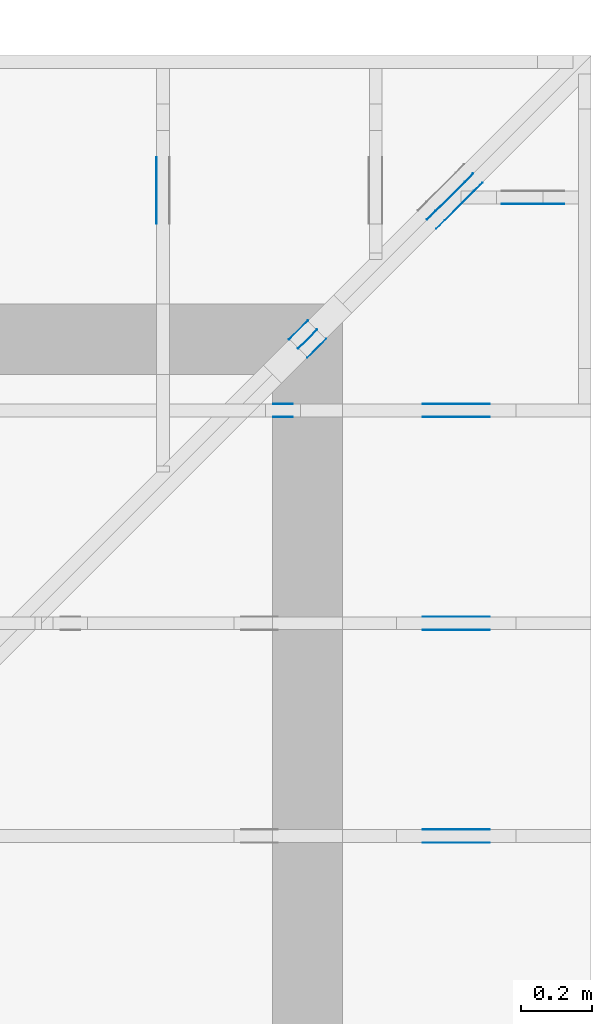
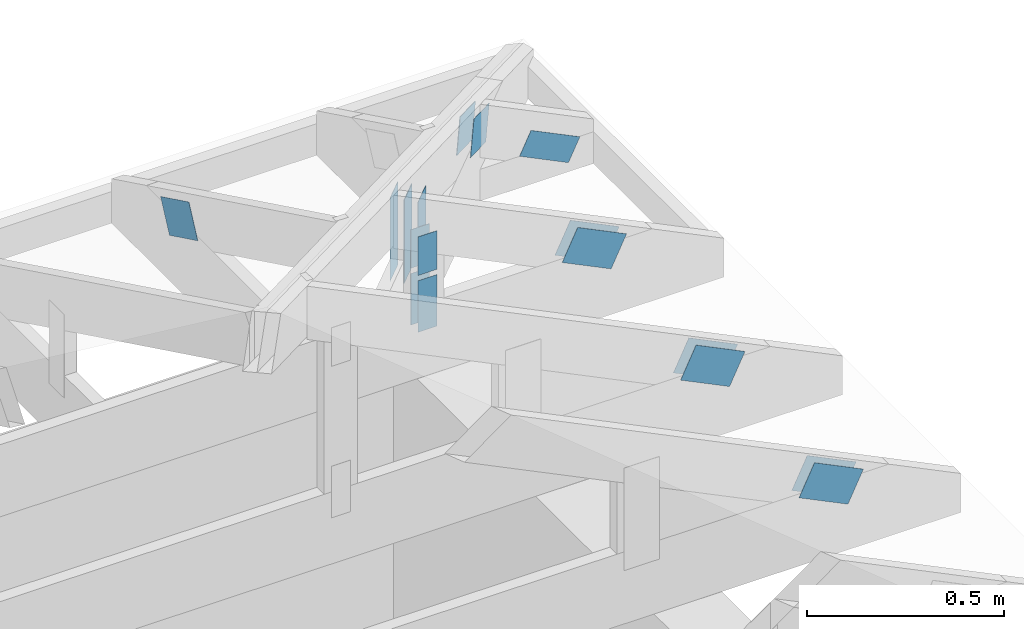
# One storey, part 135 of 159: 19 plates, 6 elements without a shape of their own.
"""IFC2X3 building model written with IfcOpenShell, lengths in millimetres."""

import ifcopenshell
import ifcopenshell.guid

model = None  # the IFC model being written
_history = None  # IfcOwnerHistory: only IFC2X3 demands one
_inside = {}  # id of a spatial element -> (the spatial element, [elements in it])
_under = {}  # id of a project, library or spatial element -> (it, [spatial elements below it])
_declared = {}  # id of a project -> (the project, [libraries it declares])
_typed = {}  # id of a type object -> (the type object, [elements of that type])
_made_of = {}  # id of a material, layer set ... -> (it, [elements and type objects made of it])


def new_model(schema):
    """Start an empty IFC model of exactly this schema.

    Asked for "IFC4X3", IfcOpenShell would pick the latest addendum, in which some entities
    have other attributes; the version numbers below select the first issue.
    IFC2X3 requires an IfcOwnerHistory on every rooted entity: one is made here for all.
    """
    global model, _history
    if schema == "IFC4X3":
        model = ifcopenshell.file(schema_version=(4, 3, 0, 0))
    else:
        model = ifcopenshell.file(schema=schema)
    _inside.clear()
    _under.clear()
    _declared.clear()
    _typed.clear()
    _made_of.clear()
    _history = None
    if model.schema == "IFC2X3":
        org = make("IfcOrganization", Name="unknown")
        user = make(
            "IfcPersonAndOrganization",
            ThePerson=make("IfcPerson", FamilyName="unknown"),
            TheOrganization=org,
        )
        app = make(
            "IfcApplication",
            ApplicationDeveloper=org,
            Version="unknown",
            ApplicationFullName="unknown",
            ApplicationIdentifier="unknown",
        )
        _history = make(
            "IfcOwnerHistory",
            OwningUser=user,
            OwningApplication=app,
            ChangeAction="ADDED",
            CreationDate=0,
        )
    return model


def make(cls, **values):
    """One entity of the class cls with the attributes given. An attribute that is None is left unset."""
    return model.create_entity(
        cls, **{name: value for name, value in values.items() if value is not None}
    )


def rooted(cls, **values):
    """An entity with a GlobalId (a new one), such as an element, a storey or a relation."""
    return make(cls, GlobalId=ifcopenshell.guid.new(), OwnerHistory=_history, **values)


def si_unit(unit_type, name, prefix=None):
    """IfcSIUnit, for example si_unit("LENGTHUNIT", "METRE", prefix="MILLI")."""
    return make("IfcSIUnit", UnitType=unit_type, Prefix=prefix, Name=name)


def assignment(units):
    """IfcUnitAssignment: the units of a project."""
    return None if units is None else make("IfcUnitAssignment", Units=units)


def point(xyz):
    """IfcCartesianPoint."""
    return None if xyz is None else make("IfcCartesianPoint", Coordinates=xyz)


def direction(xyz):
    """IfcDirection."""
    return None if xyz is None else make("IfcDirection", DirectionRatios=xyz)


def frame(location, z_axis=None, x_axis=None):
    """IfcAxis2Placement3D, a coordinate frame: its origin and axes. An axis left out is left unset."""
    return make(
        "IfcAxis2Placement3D",
        Location=point(location),
        Axis=direction(z_axis),
        RefDirection=direction(x_axis),
    )


def frame_2d(location, x_axis=None):
    """IfcAxis2Placement2D, a coordinate frame in the plane: its origin and x axis."""
    return make(
        "IfcAxis2Placement2D", Location=point(location), RefDirection=direction(x_axis)
    )


def origin():
    """The frame at (0, 0, 0) with its axes left unset."""
    return frame((0.0, 0.0, 0.0))


def origin_with_axes():
    """The frame at (0, 0, 0) with the z axis (0, 0, 1) and the x axis (1, 0, 0) written out."""
    return frame((0.0, 0.0, 0.0), z_axis=(0.0, 0.0, 1.0), x_axis=(1.0, 0.0, 0.0))


def origin_2d():
    """The frame at (0, 0) in the plane with its x axis left unset."""
    return frame_2d((0.0, 0.0))


def place(relative_to, where):
    """IfcLocalPlacement: puts the frame where relative to a parent placement (None: the world)."""
    return make(
        "IfcLocalPlacement", PlacementRelTo=relative_to, RelativePlacement=where
    )


def context(
    kind, dimensions, precision=None, world=None, true_north=None, identifier=None
):
    """IfcGeometricRepresentationContext, for example the 3D "Model" context."""
    return make(
        "IfcGeometricRepresentationContext",
        ContextIdentifier=identifier,
        ContextType=kind,
        CoordinateSpaceDimension=dimensions,
        Precision=precision,
        WorldCoordinateSystem=world,
        TrueNorth=true_north,
    )


def project(units=None, contexts=None):
    """IfcProject with its units and contexts."""
    return rooted(
        "IfcProject",
        Name="project",
        RepresentationContexts=contexts,
        UnitsInContext=assignment(units),
    )


def spatial(cls, under=None, at=None, **own):
    """A site, building, storey or space (cls), placed at a placement, below another one or the project."""
    s = rooted(cls, ObjectPlacement=at, **own)
    if under is not None:
        _under.setdefault(under.id(), (under, []))[1].append(s)
    return s


def faces_of(points, faces, orient=None, outer=None):
    """IfcFace entities. A face is a list of loops; a loop is a list of indices into points, from 0.

    orient and outer hold one flag for each loop. By default every Orientation is true, the
    first loop of a face is its IfcFaceOuterBound and the others are IfcFaceBound.
    """
    made = []
    for i, loops in enumerate(faces):
        bounds = []
        for j, loop in enumerate(loops):
            is_outer = j == 0 if outer is None else outer[i][j]
            bounds.append(
                make(
                    "IfcFaceOuterBound" if is_outer else "IfcFaceBound",
                    Bound=make("IfcPolyLoop", Polygon=[points[k] for k in loop]),
                    Orientation=True if orient is None else orient[i][j],
                )
            )
        made.append(make("IfcFace", Bounds=bounds))
    return made


def faceted_brep(points, faces, orient=None, outer=None, voids=None):
    """IfcFacetedBrep: a solid bounded by flat faces; with voids (closed shells), ...WithVoids."""
    shared = [point(p) for p in points]
    hull = make("IfcClosedShell", CfsFaces=faces_of(shared, faces, orient, outer))
    if voids is None:
        return make("IfcFacetedBrep", Outer=hull)
    return make(
        "IfcFacetedBrepWithVoids",
        Outer=hull,
        Voids=[
            make(cls, CfsFaces=faces_of(shared, fs, o, b)) for cls, fs, o, b in voids
        ],
    )


def shape(context_of_items, identifier, shape_type, items):
    """IfcShapeRepresentation: the items that make up one representation, for example the "Body"."""
    return make(
        "IfcShapeRepresentation",
        ContextOfItems=context_of_items,
        RepresentationIdentifier=identifier,
        RepresentationType=shape_type,
        Items=items,
    )


def made_of(thing, what):
    """Note that an element or type object is made of a material, layer set ...; save() writes the relation."""
    if what is not None:
        _made_of.setdefault(what.id(), (what, []))[1].append(thing)
    return thing


def element(
    cls,
    number,
    at=None,
    inside=None,
    cuts=None,
    type_object=None,
    material=None,
    context=None,
    identifier="Body",
    shape_type=None,
    held_by="IfcProductDefinitionShape",
    body=None,
    shapes=None,
    **own,
):
    """One element of the class cls, such as IfcWall. Its Tag is "e" and its number.

    at: its placement. inside: the storey or other place that contains it. cuts: it is an
    opening in that element (IfcRelVoidsElement). A single representation is given by context,
    identifier, shape_type and body (its items); several are given by shapes. held_by: the class
    of the entity that holds the representations. save() writes the other relations.
    """
    e = rooted(cls, Tag="e%d" % number, ObjectPlacement=at, **own)
    if body is not None:
        shapes = [shape(context, identifier, shape_type, body)]
    if shapes is not None:
        e.Representation = make(held_by, Representations=shapes)
    if inside is not None:
        _inside.setdefault(inside.id(), (inside, []))[1].append(e)
    if cuts is not None:
        rooted(
            "IfcRelVoidsElement", RelatingBuildingElement=cuts, RelatedOpeningElement=e
        )
    if type_object is not None:
        _typed.setdefault(type_object.id(), (type_object, []))[1].append(e)
    return made_of(e, material)


def aggregate(whole, parts):
    """IfcRelAggregates: a whole, such as a stair, and the parts it consists of."""
    return rooted("IfcRelAggregates", RelatingObject=whole, RelatedObjects=parts)


def save(model, path):
    """Write the relations noted so far, then the file.

    IfcRelAggregates (storeys below a building ...), IfcRelContainedInSpatialStructure (elements
    in a storey), IfcRelDefinesByType, IfcRelAssociatesMaterial and IfcRelDeclares: one each for
    every whole, place, type object, material and project.
    """
    for whole, parts in _under.values():
        aggregate(whole, parts)
    for where, things in _inside.values():
        rooted(
            "IfcRelContainedInSpatialStructure",
            RelatedElements=things,
            RelatingStructure=where,
        )
    for kind, things in _typed.values():
        rooted("IfcRelDefinesByType", RelatedObjects=things, RelatingType=kind)
    for what, things in _made_of.values():
        rooted("IfcRelAssociatesMaterial", RelatedObjects=things, RelatingMaterial=what)
    for by, libraries in _declared.values():
        rooted("IfcRelDeclares", RelatingContext=by, RelatedDefinitions=libraries)
    model.write(path)


model = new_model("IFC2X3")

# Units and contexts
model_context = context("Model", 3, precision=1e-05, world=origin())
plan_context = context("Plan", 2, precision=1e-05, world=origin_2d())
ifc_project = project(units=[si_unit("LENGTHUNIT", "METRE", prefix="MILLI"), si_unit("AREAUNIT", "SQUARE_METRE"), si_unit("VOLUMEUNIT", "CUBIC_METRE"), si_unit("SOLIDANGLEUNIT", "STERADIAN"), si_unit("PLANEANGLEUNIT", "RADIAN"), si_unit("MASSUNIT", "GRAM"), si_unit("TIMEUNIT", "SECOND"), si_unit("THERMODYNAMICTEMPERATUREUNIT", "DEGREE_CELSIUS"), si_unit("LUMINOUSINTENSITYUNIT", "LUMEN")], contexts=[model_context, plan_context])

# Site, building, storey
site_placement = place(None, origin_with_axes())
site = spatial("IfcSite", under=ifc_project, at=site_placement, CompositionType="ELEMENT")
building_placement = place(site_placement, origin_with_axes())
building = spatial("IfcBuilding", under=site, at=building_placement, Name="Plan 1", CompositionType="ELEMENT")
storey_placement = place(building_placement, origin_with_axes())
storey = spatial("IfcBuildingStorey", under=building, at=storey_placement, Name="Etasje 1", CompositionType="ELEMENT", Elevation=0.0)

# Assembly, plate
assembly_1_placement = place(storey_placement, frame((19875.02226140475, 9663.999999999993, 1.1021457184401395e-15), z_axis=(-1.0, 1.836909530733566e-16, 6.123031769111886e-17), x_axis=(-1.836909530733566e-16, -1.0, 0.0)))
assembly_1 = element("IfcElementAssembly", 1, at=assembly_1_placement, inside=storey, Name="S22 (57)", AssemblyPlace="FACTORY", PredefinedType="TRUSS")
plate_1_placement = place(assembly_1_placement, frame((295.1100155272948, 141.8615890385072, 0.0), z_axis=(0.0, 0.0, 1.0), x_axis=(0.898794046299167, 0.4383711467890774, 0.0)))
plate_1 = element("IfcPlate", 2, at=plate_1_placement, Name="GNT100S 103x159", context=model_context, shape_type="Brep", body=[
    faceted_brep([(158.9999923478332, 103.00001933830698, 1.0), (0.0, 103.00001933830698, 1.0), (6.332527107133501e-06, 1.220379553501516e-05, 1.0), (159.00001239486903, 1.220379553501516e-05, 1.0), (0.0, 103.00001933830698, 0.0), (158.9999923478332, 103.00001933830698, 1.947124008868659e-14), (159.00001239486903, 0.0, 1.9471242543659335e-14), (6.332527107133501e-06, 0.0, 7.754852931148123e-22), (159.0000031613913, 1.1149930599355426e-05, 4.8075179880833783e-32), (159.0000031613913, 1.1149930599416657e-05, 1.0), (3.1613913051842246e-06, 1.1149930628623518e-05, 1.0), (3.1613913051842246e-06, 1.1149930628562288e-05, 0.0), (159.0000031613913, 103.00001114993066, 0.0), (159.0000031613913, 103.00001114993066, 1.0), (159.0000031613913, 1.1149930600140578e-05, 1.0), (159.0000031613913, 1.1149930600140578e-05, 0.0), (3.1613913051842246e-06, 103.00001114993063, 0.0), (3.1613913051842246e-06, 103.00001114993063, 1.0), (159.0000031613913, 103.00001114993066, 1.0), (159.0000031613913, 103.00001114993066, 0.0), (3.161391305184226e-06, 1.1149930628562288e-05, -9.4039548065783e-38), (3.161391305245456e-06, 1.1149930628562288e-05, 1.0), (3.1613913178589017e-06, 103.00001114993063, 1.0), (3.1613913177976713e-06, 103.00001114993063, -7.723253437374298e-31)], [[[0, 1, 2, 3]], [[4, 5, 6, 7]], [[8, 9, 10, 11]], [[12, 13, 14, 15]], [[16, 17, 18, 19]], [[20, 21, 22, 23]]]),
])
aggregate(assembly_1, [plate_1])

# Assembly, plates
assembly_2_placement = place(storey_placement, frame((21100.012663101486, 8717.993668449257, 1.1021457184401395e-15), z_axis=(1.2246063538223773e-16, 1.0, 6.123031769111886e-17), x_axis=(-1.0, 1.2246063538223773e-16, 0.0)))
assembly_2 = element("IfcElementAssembly", 3, at=assembly_2_placement, inside=storey, Name="S20 (50)", AssemblyPlace="FACTORY", PredefinedType="TRUSS")
plate_2_placement = place(assembly_2_placement, frame((331.11001837099207, 141.86159042547106, 0.0), z_axis=(0.0, 0.0, 1.0), x_axis=(0.8987940462991673, 0.43837114678907685, 0.0)))
plate_2 = element("IfcPlate", 4, at=plate_2_placement, Name="GNT100S 103x159", context=model_context, shape_type="Brep", body=[
    faceted_brep([(158.99998918392998, 103.00001264929405, 1.0), (1.0550605622938747e-05, 103.00001264929405, 1.0), (3.168624004956655e-06, 1.2203795492382596e-05, 1.0), (159.00000923096593, 1.2203795492382596e-05, 1.0), (1.0550605622938747e-05, 103.00001264929405, 1.292033868252489e-21), (158.99998918392998, 103.00001264929405, 1.9471239701232992e-14), (159.00000923096593, 0.0, 1.947124215620575e-14), (3.168624004956655e-06, 0.0, 3.8803170893440275e-22), (159.0000000000001, 1.1148705922106925e-05, 2.6584805324637452e-30), (159.0000000000001, 1.1148705922168155e-05, 1.0), (5.684341886080802e-14, 1.1148705951375017e-05, 1.0), (5.684341886080802e-14, 1.1148705951313786e-05, 0.0), (159.0000000000001, 103.00001114870594, 0.0), (159.0000000000001, 103.00001114870594, 1.0), (159.0000000000001, 1.1148705965524641e-05, 1.0), (159.0000000000001, 1.1148705965524641e-05, 0.0), (-4.861730685829017e-63, 103.00001114870594, 0.0), (-3.7491518045553436e-33, 103.00001114870594, 1.0), (159.0000000000001, 103.00001114870592, 1.0), (159.0000000000001, 103.00001114870592, -7.888609052210118e-31), (5.684342142778951e-14, 1.1148705951313786e-05, -1.5717709276844939e-37), (5.690465174548063e-14, 1.1148705951313786e-05, 1.0), (2.377690857529467e-14, 103.00001114870594, 1.0), (2.3715678257603552e-14, 103.00001114870594, -1.4521185139734257e-30)], [[[0, 1, 2, 3]], [[4, 5, 6, 7]], [[8, 9, 10, 11]], [[12, 13, 14, 15]], [[16, 17, 18, 19]], [[20, 21, 22, 23]]]),
])
plate_3_placement = place(assembly_2_placement, frame((331.11001837099207, 141.86159042547106, -37.0), z_axis=(0.0, 0.0, 1.0), x_axis=(0.8987940462991673, 0.43837114678907685, 0.0)))
plate_3 = element("IfcPlate", 5, at=plate_3_placement, Name="GNT100S 103x159", context=model_context, shape_type="Brep", body=[
    faceted_brep([(158.99998918392998, 103.00001264929405, 1.0), (1.0550605622938747e-05, 103.00001264929405, 1.0), (3.168624004956655e-06, 1.2203795492382596e-05, 1.0), (159.00000923096593, 1.2203795492382596e-05, 1.0), (1.0550605622938747e-05, 103.00001264929405, 1.292033868252489e-21), (158.99998918392998, 103.00001264929405, 1.9471239701232992e-14), (159.00000923096593, 0.0, 1.947124215620575e-14), (3.168624004956655e-06, 0.0, 3.8803170893440275e-22), (159.0000000000001, 1.1148705922106925e-05, 2.6584805324637452e-30), (159.0000000000001, 1.1148705922168155e-05, 1.0), (5.684341886080802e-14, 1.1148705951375017e-05, 1.0), (5.684341886080802e-14, 1.1148705951313786e-05, 0.0), (159.0000000000001, 103.00001114870594, 0.0), (159.0000000000001, 103.00001114870594, 1.0), (159.0000000000001, 1.1148705965524641e-05, 1.0), (159.0000000000001, 1.1148705965524641e-05, 0.0), (-4.861730685829017e-63, 103.00001114870594, 0.0), (-3.7491518045553436e-33, 103.00001114870594, 1.0), (159.0000000000001, 103.00001114870592, 1.0), (159.0000000000001, 103.00001114870592, -7.888609052210118e-31), (5.684342142778951e-14, 1.1148705951313786e-05, -1.5717709276844939e-37), (5.690465174548063e-14, 1.1148705951313786e-05, 1.0), (2.377690857529467e-14, 103.00001114870594, 1.0), (2.3715678257603552e-14, 103.00001114870594, -1.4521185139734257e-30)], [[[0, 1, 2, 3]], [[4, 5, 6, 7]], [[8, 9, 10, 11]], [[12, 13, 14, 15]], [[16, 17, 18, 19]], [[20, 21, 22, 23]]]),
])
plate_4_placement = place(assembly_2_placement, frame((840.5946433071188, 438.23297119140625, 0.0), z_axis=(0.0, 0.0, 1.0), x_axis=(6.123031769111886e-17, -1.0, 0.0)))
plate_4 = element("IfcPlate", 6, at=plate_4_placement, Name="GNT100S 55x119", context=model_context, shape_type="Brep", body=[
    faceted_brep([(119.0, 55.00002222022499, 1.0), (0.0, 55.00002222022499, 1.0), (0.0, 2.2220224991542636e-05, 1.0), (119.0, 2.2220224991542636e-05, 1.0), (0.0, 55.00002222022499, 0.0), (119.0, 55.00002222022499, 1.457281561048629e-14), (119.0, 2.2220224991542636e-05, 1.457281561048629e-14), (0.0, 2.2220224991542636e-05, 0.0), (119.0000108822561, -2.185922541470143e-14, 1.3384473166239481e-30), (119.0000108822561, -2.1797995097010312e-14, 1.0), (1.088225610601512e-05, 6.122831871912316e-17, 1.0), (1.088225610601512e-05, -1.9989719957022716e-21, 1.2239769035249998e-37), (119.0000108822561, 55.0, 0.0), (119.0000108822561, 55.0, 1.0), (119.0000108822561, 0.0, 1.0), (119.0000108822561, 0.0, 0.0), (1.088225610601512e-05, 55.0, 0.0), (1.088225610601512e-05, 55.0, 1.0), (119.0000108822561, 54.99999999999999, 1.0), (119.0000108822561, 54.99999999999999, -3.944304526105059e-31), (1.088225610601512e-05, 0.0, 0.0), (1.088225610607635e-05, -7.498303609110687e-33, 1.0), (1.0882256112811685e-05, 55.0, 1.0), (1.0882256112750455e-05, 55.0, -4.124066764605687e-31)], [[[0, 1, 2, 3]], [[4, 5, 6, 7]], [[8, 9, 10, 11]], [[12, 13, 14, 15]], [[16, 17, 18, 19]], [[20, 21, 22, 23]]]),
])
plate_5_placement = place(assembly_2_placement, frame((840.5946433071188, 438.23297119140625, -37.0), z_axis=(0.0, 0.0, 1.0), x_axis=(6.123031769111886e-17, -1.0, 0.0)))
plate_5 = element("IfcPlate", 7, at=plate_5_placement, Name="GNT100S 55x119", context=model_context, shape_type="Brep", body=[
    faceted_brep([(119.0, 55.00002222022499, 1.0), (0.0, 55.00002222022499, 1.0), (0.0, 2.2220224991542636e-05, 1.0), (119.0, 2.2220224991542636e-05, 1.0), (0.0, 55.00002222022499, 0.0), (119.0, 55.00002222022499, 1.457281561048629e-14), (119.0, 2.2220224991542636e-05, 1.457281561048629e-14), (0.0, 2.2220224991542636e-05, 0.0), (119.0000108822561, -2.185922541470143e-14, 1.3384473166239481e-30), (119.0000108822561, -2.1797995097010312e-14, 1.0), (1.088225610601512e-05, 6.122831871912316e-17, 1.0), (1.088225610601512e-05, -1.9989719957022716e-21, 1.2239769035249998e-37), (119.0000108822561, 55.0, 0.0), (119.0000108822561, 55.0, 1.0), (119.0000108822561, 0.0, 1.0), (119.0000108822561, 0.0, 0.0), (1.088225610601512e-05, 55.0, 0.0), (1.088225610601512e-05, 55.0, 1.0), (119.0000108822561, 54.99999999999999, 1.0), (119.0000108822561, 54.99999999999999, -3.944304526105059e-31), (1.088225610601512e-05, 0.0, 0.0), (1.088225610607635e-05, -7.498303609110687e-33, 1.0), (1.0882256112811685e-05, 55.0, 1.0), (1.0882256112750455e-05, 55.0, -4.124066764605687e-31)], [[[0, 1, 2, 3]], [[4, 5, 6, 7]], [[8, 9, 10, 11]], [[12, 13, 14, 15]], [[16, 17, 18, 19]], [[20, 21, 22, 23]]]),
])
plate_6_placement = place(assembly_2_placement, frame((895.5946655273438, 143.5, 0.0), z_axis=(0.0, 0.0, 1.0), x_axis=(6.123031769111886e-17, 1.0, 0.0)))
plate_6 = element("IfcPlate", 8, at=plate_6_placement, Name="GNT100S 55x159", context=model_context, shape_type="Brep", body=[
    faceted_brep([(159.0, 55.0, 1.0), (0.0, 55.0, 1.0), (0.0, 0.0, 1.0), (159.0, 0.0, 1.0), (0.0, 55.0, 0.0), (159.0, 55.0, 1.9471241025775798e-14), (159.0, 0.0, 1.9471241025775798e-14), (0.0, 0.0, 0.0), (159.0, 2.2220192447900186e-05, 1.788345383589592e-30), (159.0, 2.2220192447961417e-05, 1.0), (1.1247455413666031e-32, 2.222019247716828e-05, 1.0), (0.0, 2.2220192477107048e-05, 0.0), (159.0, 55.00002222019248, 0.0), (159.0, 55.00002222019248, 1.0), (159.0, 2.2220192477107048e-05, 1.0), (159.0, 2.2220192477107048e-05, 0.0), (0.0, 55.00002222019248, 0.0), (-3.7491518045553436e-33, 55.00002222019248, 1.0), (159.0, 55.00002222019247, 1.0), (159.0, 55.00002222019247, -7.888609052210118e-31), (2.721098889062148e-21, 2.2220192477107048e-05, -1.6661374944622592e-37), (6.123303879000793e-17, 2.2220192477107048e-05, 1.0), (6.796567984813083e-15, 55.00002222019248, 1.0), (6.735337667121964e-15, 55.00002222019248, -4.124068651148373e-31)], [[[0, 1, 2, 3]], [[4, 5, 6, 7]], [[8, 9, 10, 11]], [[12, 13, 14, 15]], [[16, 17, 18, 19]], [[20, 21, 22, 23]]]),
])
plate_7_placement = place(assembly_2_placement, frame((895.5946655273438, 143.5, -37.0), z_axis=(0.0, 0.0, 1.0), x_axis=(6.123031769111886e-17, 1.0, 0.0)))
plate_7 = element("IfcPlate", 9, at=plate_7_placement, Name="GNT100S 55x159", context=model_context, shape_type="Brep", body=[
    faceted_brep([(159.0, 55.0, 1.0), (0.0, 55.0, 1.0), (0.0, 0.0, 1.0), (159.0, 0.0, 1.0), (0.0, 55.0, 0.0), (159.0, 55.0, 1.9471241025775798e-14), (159.0, 0.0, 1.9471241025775798e-14), (0.0, 0.0, 0.0), (159.0, 2.2220192447900186e-05, 1.788345383589592e-30), (159.0, 2.2220192447961417e-05, 1.0), (1.1247455413666031e-32, 2.222019247716828e-05, 1.0), (0.0, 2.2220192477107048e-05, 0.0), (159.0, 55.00002222019248, 0.0), (159.0, 55.00002222019248, 1.0), (159.0, 2.2220192477107048e-05, 1.0), (159.0, 2.2220192477107048e-05, 0.0), (0.0, 55.00002222019248, 0.0), (-3.7491518045553436e-33, 55.00002222019248, 1.0), (159.0, 55.00002222019247, 1.0), (159.0, 55.00002222019247, -7.888609052210118e-31), (2.721098889062148e-21, 2.2220192477107048e-05, -1.6661374944622592e-37), (6.123303879000793e-17, 2.2220192477107048e-05, 1.0), (6.796567984813083e-15, 55.00002222019248, 1.0), (6.735337667121964e-15, 55.00002222019248, -4.124068651148373e-31)], [[[0, 1, 2, 3]], [[4, 5, 6, 7]], [[8, 9, 10, 11]], [[12, 13, 14, 15]], [[16, 17, 18, 19]], [[20, 21, 22, 23]]]),
])
aggregate(assembly_2, [plate_2, plate_3, plate_4, plate_5, plate_6, plate_7])

assembly_3_placement = place(storey_placement, frame((21100.012663101486, 8117.993668449257, 1.1021457184401395e-15), z_axis=(1.2246063538223773e-16, 1.0, 6.123031769111886e-17), x_axis=(-1.0, 1.2246063538223773e-16, 0.0)))
assembly_3 = element("IfcElementAssembly", 10, at=assembly_3_placement, inside=storey, Name="S19 (48)", AssemblyPlace="FACTORY", PredefinedType="TRUSS")
plate_8_placement = place(assembly_3_placement, frame((331.1100183702398, 141.86159042510417, 0.0), z_axis=(0.0, 0.0, 1.0), x_axis=(0.8987940462991671, 0.438371146789077, 0.0)))
plate_8 = element("IfcPlate", 11, at=plate_8_placement, Name="GNT100S 103x159", context=model_context, shape_type="Brep", body=[
    faceted_brep([(158.99998918476706, 103.00001264929404, 1.0), (1.0551442642281472e-05, 103.00001264929404, 1.0), (3.1694609106125426e-06, 1.2203795478171742e-05, 1.0), (159.0000092318029, 1.2203795478171742e-05, 1.0), (1.0551442642281472e-05, 103.00001264929404, 1.2921363701730264e-21), (158.99998918476706, 103.00001264929404, 1.94712397013355e-14), (159.0000092318029, 0.0, 1.9471242156308246e-14), (3.1694609106125426e-06, 0.0, 3.8813419693277774e-22), (159.0, 1.1149114185752038e-05, 1.788345383589592e-30), (159.0, 1.1149114185813268e-05, 1.0), (1.1247455413666031e-32, 1.114911421502013e-05, 1.0), (0.0, 1.11491142149589e-05, 0.0), (159.0, 103.00001114911421, 0.0), (159.0, 103.00001114911421, 1.0), (159.0, 1.11491142149589e-05, 1.0), (159.0, 1.11491142149589e-05, 0.0), (0.0, 103.00001114911421, 0.0), (-3.7491518045553436e-33, 103.00001114911421, 1.0), (159.0, 103.0000111491142, 1.0), (159.0, 103.0000111491142, -7.888609052210118e-31), (1.3653276107130054e-21, 1.11491142149589e-05, -8.359944335641358e-38), (6.123168301872958e-17, 1.11491142149589e-05, 1.0), (1.2674677127389216e-14, 103.00001114911421, 1.0), (1.2613446809698097e-14, 103.00001114911421, -7.723253553378441e-31)], [[[0, 1, 2, 3]], [[4, 5, 6, 7]], [[8, 9, 10, 11]], [[12, 13, 14, 15]], [[16, 17, 18, 19]], [[20, 21, 22, 23]]]),
])
plate_9_placement = place(assembly_3_placement, frame((331.1100183702398, 141.86159042510417, -36.99999999999999), z_axis=(0.0, 0.0, 1.0), x_axis=(0.8987940462991671, 0.438371146789077, 0.0)))
plate_9 = element("IfcPlate", 12, at=plate_9_placement, Name="GNT100S 103x159", context=model_context, shape_type="Brep", body=[
    faceted_brep([(158.99998918476706, 103.00001264929404, 1.0), (1.0551442642281472e-05, 103.00001264929404, 1.0), (3.1694609106125426e-06, 1.2203795478171742e-05, 1.0), (159.0000092318029, 1.2203795478171742e-05, 1.0), (1.0551442642281472e-05, 103.00001264929404, 1.2921363701730264e-21), (158.99998918476706, 103.00001264929404, 1.94712397013355e-14), (159.0000092318029, 0.0, 1.9471242156308246e-14), (3.1694609106125426e-06, 0.0, 3.8813419693277774e-22), (159.0, 1.1149114185752038e-05, 1.788345383589592e-30), (159.0, 1.1149114185813268e-05, 1.0), (1.1247455413666031e-32, 1.114911421502013e-05, 1.0), (0.0, 1.11491142149589e-05, 0.0), (159.0, 103.00001114911421, 0.0), (159.0, 103.00001114911421, 1.0), (159.0, 1.11491142149589e-05, 1.0), (159.0, 1.11491142149589e-05, 0.0), (0.0, 103.00001114911421, 0.0), (-3.7491518045553436e-33, 103.00001114911421, 1.0), (159.0, 103.0000111491142, 1.0), (159.0, 103.0000111491142, -7.888609052210118e-31), (1.3653276107130054e-21, 1.11491142149589e-05, -8.359944335641358e-38), (6.123168301872958e-17, 1.11491142149589e-05, 1.0), (1.2674677127389216e-14, 103.00001114911421, 1.0), (1.2613446809698097e-14, 103.00001114911421, -7.723253553378441e-31)], [[[0, 1, 2, 3]], [[4, 5, 6, 7]], [[8, 9, 10, 11]], [[12, 13, 14, 15]], [[16, 17, 18, 19]], [[20, 21, 22, 23]]]),
])
aggregate(assembly_3, [plate_8, plate_9])

assembly_4_placement = place(storey_placement, frame((21100.012663101486, 7517.993668449257, 1.1021457184401395e-15), z_axis=(1.2246063538223773e-16, 1.0, 6.123031769111886e-17), x_axis=(-1.0, 1.2246063538223773e-16, 0.0)))
assembly_4 = element("IfcElementAssembly", 13, at=assembly_4_placement, inside=storey, Name="S18 (46)", AssemblyPlace="FACTORY", PredefinedType="TRUSS")
plate_10_placement = place(assembly_4_placement, frame((331.1100183709922, 141.86159042547115, 0.0), z_axis=(0.0, 0.0, 1.0), x_axis=(0.8987940462991671, 0.4383711467890766, 0.0)))
plate_10 = element("IfcPlate", 14, at=plate_10_placement, Name="GNT100S 103x159", context=model_context, shape_type="Brep", body=[
    faceted_brep([(158.9999891839298, 103.00001264929402, 1.0), (1.055060545240849e-05, 103.00001264929402, 1.0), (3.1686238912698172e-06, 1.2203795449750032e-05, 1.0), (159.00000923096587, 1.2203795449750032e-05, 1.0), (1.055060545240849e-05, 103.00001264929402, 1.2920338473692454e-21), (158.9999891839298, 103.00001264929402, 1.947123970123297e-14), (159.00000923096587, 0.0, 1.9471242156205745e-14), (3.1686238912698172e-06, 0.0, 3.8803169501224037e-22), (158.99999999999994, 1.114870593631778e-05, 3.5286156813378984e-30), (158.99999999999994, 1.114870593637901e-05, 1.0), (1.124750610685991e-32, 1.1148705965585872e-05, 1.0), (0.0, 1.1148705965524641e-05, 0.0), (158.99999999999994, 103.00001114870602, 0.0), (158.99999999999994, 103.00001114870602, 1.0), (158.99999999999994, 1.114870599394635e-05, 1.0), (158.99999999999994, 1.114870599394635e-05, 0.0), (0.0, 103.00001114870598, 0.0), (0.0, 103.00001114870598, 1.0), (158.99999999999994, 103.00001114870601, 1.0), (158.99999999999994, 103.00001114870601, -7.888609052210118e-31), (1.3652776162278917e-21, 1.1148705965524641e-05, -8.359638217820727e-38), (6.123168296873509e-17, 1.1148705965524641e-05, 1.0), (1.2674677127339223e-14, 103.00001114870598, 1.0), (1.2613446809648104e-14, 103.00001114870598, -7.723253553347831e-31)], [[[0, 1, 2, 3]], [[4, 5, 6, 7]], [[8, 9, 10, 11]], [[12, 13, 14, 15]], [[16, 17, 18, 19]], [[20, 21, 22, 23]]]),
])
plate_11_placement = place(assembly_4_placement, frame((331.1100183709922, 141.86159042547115, -37.0), z_axis=(0.0, 0.0, 1.0), x_axis=(0.8987940462991671, 0.4383711467890766, 0.0)))
plate_11 = element("IfcPlate", 15, at=plate_11_placement, Name="GNT100S 103x159", context=model_context, shape_type="Brep", body=[
    faceted_brep([(158.9999891839298, 103.00001264929402, 1.0), (1.055060545240849e-05, 103.00001264929402, 1.0), (3.1686238912698172e-06, 1.2203795449750032e-05, 1.0), (159.00000923096587, 1.2203795449750032e-05, 1.0), (1.055060545240849e-05, 103.00001264929402, 1.2920338473692454e-21), (158.9999891839298, 103.00001264929402, 1.947123970123297e-14), (159.00000923096587, 0.0, 1.9471242156205745e-14), (3.1686238912698172e-06, 0.0, 3.8803169501224037e-22), (158.99999999999994, 1.114870593631778e-05, 3.5286156813378984e-30), (158.99999999999994, 1.114870593637901e-05, 1.0), (1.124750610685991e-32, 1.1148705965585872e-05, 1.0), (0.0, 1.1148705965524641e-05, 0.0), (158.99999999999994, 103.00001114870602, 0.0), (158.99999999999994, 103.00001114870602, 1.0), (158.99999999999994, 1.114870599394635e-05, 1.0), (158.99999999999994, 1.114870599394635e-05, 0.0), (0.0, 103.00001114870598, 0.0), (0.0, 103.00001114870598, 1.0), (158.99999999999994, 103.00001114870601, 1.0), (158.99999999999994, 103.00001114870601, -7.888609052210118e-31), (1.3652776162278917e-21, 1.1148705965524641e-05, -8.359638217820727e-38), (6.123168296873509e-17, 1.1148705965524641e-05, 1.0), (1.2674677127339223e-14, 103.00001114870598, 1.0), (1.2613446809648104e-14, 103.00001114870598, -7.723253553347831e-31)], [[[0, 1, 2, 3]], [[4, 5, 6, 7]], [[8, 9, 10, 11]], [[12, 13, 14, 15]], [[16, 17, 18, 19]], [[20, 21, 22, 23]]]),
])
aggregate(assembly_4, [plate_10, plate_11])

assembly_5_placement = place(storey_placement, frame((21074.556818978763, 9725.45584412271, 2.204291436880279e-15), z_axis=(-0.7071067811865471, 0.7071067811865479, 6.123031769111886e-17), x_axis=(-0.7071067811865479, -0.7071067811865471, 0.0)))
assembly_5 = element("IfcElementAssembly", 16, at=assembly_5_placement, inside=storey, Name="GR1 (36)", AssemblyPlace="FACTORY", PredefinedType="TRUSS")
plate_12_placement = place(assembly_5_placement, frame((503.2603454589843, 148.39434814453122, -36.99999999999999), z_axis=(0.0, 0.0, 1.0), x_axis=(0.9453579955214152, 0.32603413978252627, 0.0)))
plate_12 = element("IfcPlate", 17, at=plate_12_placement, Name="GNT100S 103x159", context=model_context, shape_type="Brep", body=[
    faceted_brep([(158.99997445489055, 102.99999720977215, 1.0), (3.2122421771418885e-06, 102.99999720977215, 1.0), (0.0, 0.0, 1.0), (159.0000000926849, 0.0, 1.0), (3.2122421771418885e-06, 102.99999720977215, 3.933732180144183e-22), (158.99997445489055, 102.99999720977215, 1.9471237897505463e-14), (159.0000000926849, 3.709764143877692e-06, 1.947124103712605e-14), (0.0, 3.709764143877692e-06, 0.0), (159.00000083894315, 7.403347971255388e-07, 3.5286157224802006e-30), (159.00000083894315, 7.403347971867691e-07, 1.0), (8.389431513933233e-07, 7.403348263936307e-07, 1.0), (8.389431513933233e-07, 7.403348263324003e-07, 1.7632415262334313e-38), (159.00000083894315, 103.0000007403348, 0.0), (159.00000083894315, 103.0000007403348, 1.0), (159.00000083894315, 7.4033485475411e-07, 1.0), (159.00000083894315, 7.4033485475411e-07, 0.0), (8.389431513933232e-07, 103.00000074033483, 0.0), (8.389431513933232e-07, 103.00000074033483, 1.0), (159.00000083894315, 103.00000074033478, 1.0), (159.00000083894315, 103.00000074033478, -7.888609052210118e-31), (8.389431513933233e-07, 7.403348263324006e-07, -5.877471754111438e-39), (8.389431514545536e-07, 7.403348263324006e-07, 1.0), (8.389431640679991e-07, 103.00000074033483, 1.0), (8.389431640067688e-07, 103.00000074033483, -7.723252790852405e-31)], [[[0, 1, 2, 3]], [[4, 5, 6, 7]], [[8, 9, 10, 11]], [[12, 13, 14, 15]], [[16, 17, 18, 19]], [[20, 21, 22, 23]]]),
])
plate_13_placement = place(assembly_5_placement, frame((503.2603454589843, 148.39434814453122, -35.99999999999999), z_axis=(0.0, 0.0, 1.0), x_axis=(0.9453579955214152, 0.32603413978252627, 0.0)))
plate_13 = element("IfcPlate", 18, at=plate_13_placement, Name="GNT100S 103x159", context=model_context, shape_type="Brep", body=[
    faceted_brep([(158.99997445489055, 102.99999720977215, 1.0), (3.2122421771418885e-06, 102.99999720977215, 1.0), (0.0, 0.0, 1.0), (159.0000000926849, 0.0, 1.0), (3.2122421771418885e-06, 102.99999720977215, 3.933732180144183e-22), (158.99997445489055, 102.99999720977215, 1.9471237897505463e-14), (159.0000000926849, 3.709764143877692e-06, 1.947124103712605e-14), (0.0, 3.709764143877692e-06, 0.0), (159.00000083894315, 7.403347971255388e-07, 3.5286157224802006e-30), (159.00000083894315, 7.403347971867691e-07, 1.0), (8.389431513933233e-07, 7.403348263936307e-07, 1.0), (8.389431513933233e-07, 7.403348263324003e-07, 1.7632415262334313e-38), (159.00000083894315, 103.0000007403348, 0.0), (159.00000083894315, 103.0000007403348, 1.0), (159.00000083894315, 7.4033485475411e-07, 1.0), (159.00000083894315, 7.4033485475411e-07, 0.0), (8.389431513933232e-07, 103.00000074033483, 0.0), (8.389431513933232e-07, 103.00000074033483, 1.0), (159.00000083894315, 103.00000074033478, 1.0), (159.00000083894315, 103.00000074033478, -7.888609052210118e-31), (8.389431513933233e-07, 7.403348263324006e-07, -5.877471754111438e-39), (8.389431514545536e-07, 7.403348263324006e-07, 1.0), (8.389431640679991e-07, 103.00000074033483, 1.0), (8.389431640067688e-07, 103.00000074033483, -7.723252790852405e-31)], [[[0, 1, 2, 3]], [[4, 5, 6, 7]], [[8, 9, 10, 11]], [[12, 13, 14, 15]], [[16, 17, 18, 19]], [[20, 21, 22, 23]]]),
])
plate_14_placement = place(assembly_5_placement, frame((503.2603454589843, 148.39434814453122, -73.0), z_axis=(0.0, 0.0, 1.0), x_axis=(0.9453579955214152, 0.32603413978252627, 0.0)))
plate_14 = element("IfcPlate", 19, at=plate_14_placement, Name="GNT100S 103x159", context=model_context, shape_type="Brep", body=[
    faceted_brep([(158.99997445489055, 102.99999720977215, 1.0), (3.2122421771418885e-06, 102.99999720977215, 1.0), (0.0, 0.0, 1.0), (159.0000000926849, 0.0, 1.0), (3.2122421771418885e-06, 102.99999720977215, 3.933732180144183e-22), (158.99997445489055, 102.99999720977215, 1.9471237897505463e-14), (159.0000000926849, 3.709764143877692e-06, 1.947124103712605e-14), (0.0, 3.709764143877692e-06, 0.0), (159.00000083894315, 7.403347971255388e-07, 3.5286157224802006e-30), (159.00000083894315, 7.403347971867691e-07, 1.0), (8.389431513933233e-07, 7.403348263936307e-07, 1.0), (8.389431513933233e-07, 7.403348263324003e-07, 1.7632415262334313e-38), (159.00000083894315, 103.0000007403348, 0.0), (159.00000083894315, 103.0000007403348, 1.0), (159.00000083894315, 7.4033485475411e-07, 1.0), (159.00000083894315, 7.4033485475411e-07, 0.0), (8.389431513933232e-07, 103.00000074033483, 0.0), (8.389431513933232e-07, 103.00000074033483, 1.0), (159.00000083894315, 103.00000074033478, 1.0), (159.00000083894315, 103.00000074033478, -7.888609052210118e-31), (8.389431513933233e-07, 7.403348263324006e-07, -5.877471754111438e-39), (8.389431514545536e-07, 7.403348263324006e-07, 1.0), (8.389431640679991e-07, 103.00000074033483, 1.0), (8.389431640067688e-07, 103.00000074033483, -7.723252790852405e-31)], [[[0, 1, 2, 3]], [[4, 5, 6, 7]], [[8, 9, 10, 11]], [[12, 13, 14, 15]], [[16, 17, 18, 19]], [[20, 21, 22, 23]]]),
])
plate_15_placement = place(assembly_5_placement, frame((1091.9566363361005, 410.8641357421875, 0.0), z_axis=(0.0, 0.0, 1.0), x_axis=(6.123031769111886e-17, -1.0, 0.0)))
plate_15 = element("IfcPlate", 20, at=plate_15_placement, Name="GNT100S 76x258", context=model_context, shape_type="Brep", body=[
    faceted_brep([(258.00001525878906, 76.00002870296203, 1.0), (0.0, 76.00002870296203, 1.0), (0.0, 2.870296202672762e-05, 1.0), (258.00001525878906, 2.870296202672762e-05, 1.0), (0.0, 76.00002870296203, 0.0), (258.00001525878906, 76.00002870296203, 3.159484579721834e-14), (258.00001525878906, 2.870296202672762e-05, 3.159484579721834e-14), (0.0, 2.870296202672762e-05, 0.0), (258.00001343312294, -4.7392268360469154e-14, 2.9018436478142872e-30), (258.00001343312294, -4.7331038042778035e-14, 1.0), (1.343312294466159e-05, 6.12278501479624e-17, 1.0), (1.343312294466159e-05, -2.467543156456462e-21, 1.5108845138637538e-37), (258.00001343312294, 76.0, 0.0), (258.00001343312294, 76.0, 1.0), (258.00001343312294, 0.0, 1.0), (258.00001343312294, 0.0, 0.0), (1.343312294466159e-05, 76.0, 0.0), (1.343312294466159e-05, 76.0, 1.0), (258.00001343312294, 75.99999999999999, 1.0), (258.00001343312294, 75.99999999999999, -7.888609052210118e-31), (1.343312294466159e-05, 0.0, 0.0), (1.3433122944722821e-05, -7.498303609110687e-33, 1.0), (1.343312295402983e-05, 76.0, 1.0), (1.3433122953968599e-05, 76.0, -5.69871103679771e-31)], [[[0, 1, 2, 3]], [[4, 5, 6, 7]], [[8, 9, 10, 11]], [[12, 13, 14, 15]], [[16, 17, 18, 19]], [[20, 21, 22, 23]]]),
])
plate_16_placement = place(assembly_5_placement, frame((1091.9566363361005, 410.8641357421875, -37.0), z_axis=(0.0, 0.0, 1.0), x_axis=(6.123031769111886e-17, -1.0, 0.0)))
plate_16 = element("IfcPlate", 21, at=plate_16_placement, Name="GNT100S 76x258", context=model_context, shape_type="Brep", body=[
    faceted_brep([(258.00001525878906, 76.00002870296203, 1.0), (0.0, 76.00002870296203, 1.0), (0.0, 2.870296202672762e-05, 1.0), (258.00001525878906, 2.870296202672762e-05, 1.0), (0.0, 76.00002870296203, 0.0), (258.00001525878906, 76.00002870296203, 3.159484579721834e-14), (258.00001525878906, 2.870296202672762e-05, 3.159484579721834e-14), (0.0, 2.870296202672762e-05, 0.0), (258.00001343312294, -4.7392268360469154e-14, 2.9018436478142872e-30), (258.00001343312294, -4.7331038042778035e-14, 1.0), (1.343312294466159e-05, 6.12278501479624e-17, 1.0), (1.343312294466159e-05, -2.467543156456462e-21, 1.5108845138637538e-37), (258.00001343312294, 76.0, 0.0), (258.00001343312294, 76.0, 1.0), (258.00001343312294, 0.0, 1.0), (258.00001343312294, 0.0, 0.0), (1.343312294466159e-05, 76.0, 0.0), (1.343312294466159e-05, 76.0, 1.0), (258.00001343312294, 75.99999999999999, 1.0), (258.00001343312294, 75.99999999999999, -7.888609052210118e-31), (1.343312294466159e-05, 0.0, 0.0), (1.3433122944722821e-05, -7.498303609110687e-33, 1.0), (1.343312295402983e-05, 76.0, 1.0), (1.3433122953968599e-05, 76.0, -5.69871103679771e-31)], [[[0, 1, 2, 3]], [[4, 5, 6, 7]], [[8, 9, 10, 11]], [[12, 13, 14, 15]], [[16, 17, 18, 19]], [[20, 21, 22, 23]]]),
])
plate_17_placement = place(assembly_5_placement, frame((1091.9566363361005, 410.8641357421875, -36.0), z_axis=(0.0, 0.0, 1.0), x_axis=(6.123031769111886e-17, -1.0, 0.0)))
plate_17 = element("IfcPlate", 22, at=plate_17_placement, Name="GNT100S 76x258", context=model_context, shape_type="Brep", body=[
    faceted_brep([(258.00001525878906, 76.00002870296203, 1.0), (0.0, 76.00002870296203, 1.0), (0.0, 2.870296202672762e-05, 1.0), (258.00001525878906, 2.870296202672762e-05, 1.0), (0.0, 76.00002870296203, 0.0), (258.00001525878906, 76.00002870296203, 3.159484579721834e-14), (258.00001525878906, 2.870296202672762e-05, 3.159484579721834e-14), (0.0, 2.870296202672762e-05, 0.0), (258.00001343312294, -4.7392268360469154e-14, 2.9018436478142872e-30), (258.00001343312294, -4.7331038042778035e-14, 1.0), (1.343312294466159e-05, 6.12278501479624e-17, 1.0), (1.343312294466159e-05, -2.467543156456462e-21, 1.5108845138637538e-37), (258.00001343312294, 76.0, 0.0), (258.00001343312294, 76.0, 1.0), (258.00001343312294, 0.0, 1.0), (258.00001343312294, 0.0, 0.0), (1.343312294466159e-05, 76.0, 0.0), (1.343312294466159e-05, 76.0, 1.0), (258.00001343312294, 75.99999999999999, 1.0), (258.00001343312294, 75.99999999999999, -7.888609052210118e-31), (1.343312294466159e-05, 0.0, 0.0), (1.3433122944722821e-05, -7.498303609110687e-33, 1.0), (1.343312295402983e-05, 76.0, 1.0), (1.3433122953968599e-05, 76.0, -5.69871103679771e-31)], [[[0, 1, 2, 3]], [[4, 5, 6, 7]], [[8, 9, 10, 11]], [[12, 13, 14, 15]], [[16, 17, 18, 19]], [[20, 21, 22, 23]]]),
])
plate_18_placement = place(assembly_5_placement, frame((1091.9566363361005, 410.8641357421875, -73.0), z_axis=(0.0, 0.0, 1.0), x_axis=(6.123031769111886e-17, -1.0, 0.0)))
plate_18 = element("IfcPlate", 23, at=plate_18_placement, Name="GNT100S 76x258", context=model_context, shape_type="Brep", body=[
    faceted_brep([(258.00001525878906, 76.00002870296203, 1.0), (0.0, 76.00002870296203, 1.0), (0.0, 2.870296202672762e-05, 1.0), (258.00001525878906, 2.870296202672762e-05, 1.0), (0.0, 76.00002870296203, 0.0), (258.00001525878906, 76.00002870296203, 3.159484579721834e-14), (258.00001525878906, 2.870296202672762e-05, 3.159484579721834e-14), (0.0, 2.870296202672762e-05, 0.0), (258.00001343312294, -4.7392268360469154e-14, 2.9018436478142872e-30), (258.00001343312294, -4.7331038042778035e-14, 1.0), (1.343312294466159e-05, 6.12278501479624e-17, 1.0), (1.343312294466159e-05, -2.467543156456462e-21, 1.5108845138637538e-37), (258.00001343312294, 76.0, 0.0), (258.00001343312294, 76.0, 1.0), (258.00001343312294, 0.0, 1.0), (258.00001343312294, 0.0, 0.0), (1.343312294466159e-05, 76.0, 0.0), (1.343312294466159e-05, 76.0, 1.0), (258.00001343312294, 75.99999999999999, 1.0), (258.00001343312294, 75.99999999999999, -7.888609052210118e-31), (1.343312294466159e-05, 0.0, 0.0), (1.3433122944722821e-05, -7.498303609110687e-33, 1.0), (1.343312295402983e-05, 76.0, 1.0), (1.3433122953968599e-05, 76.0, -5.69871103679771e-31)], [[[0, 1, 2, 3]], [[4, 5, 6, 7]], [[8, 9, 10, 11]], [[12, 13, 14, 15]], [[16, 17, 18, 19]], [[20, 21, 22, 23]]]),
])
aggregate(assembly_5, [plate_12, plate_13, plate_14, plate_15, plate_16, plate_17, plate_18])

# Assembly, plate
assembly_6_placement = place(storey_placement, frame((21064.012663098183, 9317.993668449257, 1.1021457184401395e-15), z_axis=(1.2246063538223773e-16, 1.0, 6.123031769111886e-17), x_axis=(-1.0, 1.2246063538223773e-16, 0.0)))
assembly_6 = element("IfcElementAssembly", 24, at=assembly_6_placement, inside=storey, Name="S46 (83)", AssemblyPlace="FACTORY", PredefinedType="TRUSS")
plate_19_placement = place(assembly_6_placement, frame((73.45736567453837, 28.99531874760973, -37.00000000000001), z_axis=(0.0, 0.0, 1.0), x_axis=(0.8987940462991673, 0.43837114678907735, 0.0)))
plate_19 = element("IfcPlate", 25, at=plate_19_placement, Name="GNT100S 76x159", context=model_context, shape_type="Brep", body=[
    faceted_brep([(158.99999903684605, 75.9999987703372, 1.0), (0.0, 75.9999987703372, 1.0), (1.4116927218310593e-06, 0.0, 1.0), (158.99999877628554, 0.0, 1.0), (0.0, 75.9999987703372, 0.0), (158.99999903684605, 75.9999987703372, 1.9471240907827354e-14), (158.99999877628554, 4.771098904399196e-06, 1.9471240875918947e-14), (1.4116927218310593e-06, 4.771098904399196e-06, 1.728767876799121e-22), (159.00000002767953, 1.4588112754374525e-06, 7.006764710067876e-31), (159.00000002767953, 1.4588112754986829e-06, 1.0), (2.7679575964612013e-08, 1.4588113047055444e-06, 1.0), (2.7679575964612013e-08, 1.458811304644314e-06, 0.0), (159.00000002767953, 76.00000145881128, 0.0), (159.00000002767953, 76.00000145881128, 1.0), (159.00000002767953, 1.4588112868807457e-06, 1.0), (159.00000002767953, 1.4588112868807457e-06, 0.0), (2.767959017546673e-08, 76.00000145881131, 0.0), (2.767959017546673e-08, 76.00000145881131, 1.0), (159.0000000276795, 76.00000145881127, 1.0), (159.0000000276795, 76.00000145881127, -7.888609052210118e-31), (2.767957596461192e-08, 1.458811304644314e-06, 5.510129769479473e-39), (2.7679576025842238e-08, 1.458811304644314e-06, 1.0), (2.7679585332850527e-08, 76.00000145881131, 1.0), (2.767958527162021e-08, 76.00000145881131, 3.002640800918707e-31)], [[[0, 1, 2, 3]], [[4, 5, 6, 7]], [[8, 9, 10, 11]], [[12, 13, 14, 15]], [[16, 17, 18, 19]], [[20, 21, 22, 23]]]),
])
aggregate(assembly_6, [plate_19])

save(model, "model.ifc")
